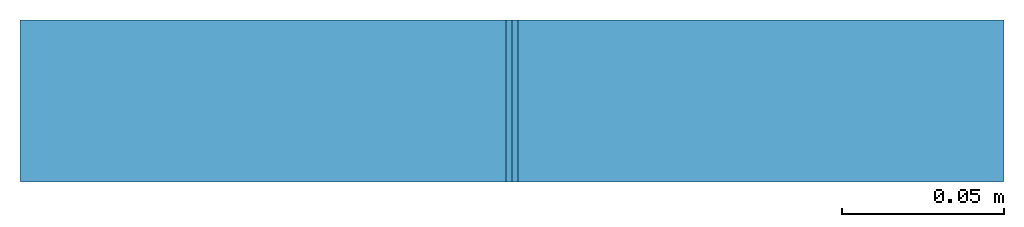
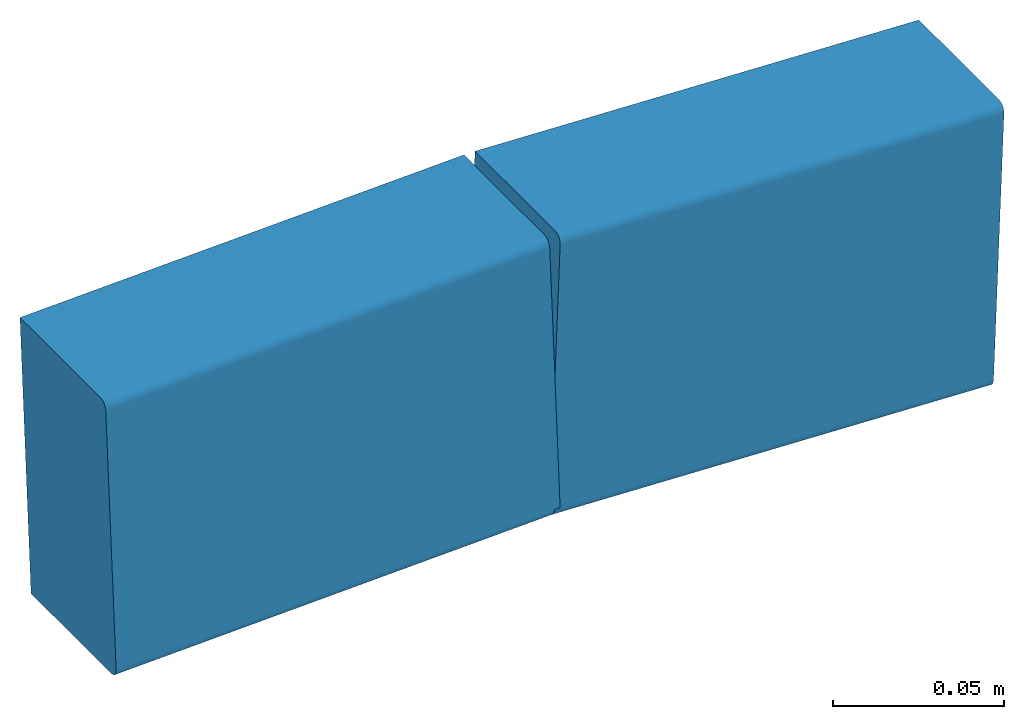
# One storey: 2 members.
"""IFC4 building model written with IfcOpenShell, lengths in metres."""

from ifc_helpers import new_model, entity, si_unit, derived_unit, frame, origin_with_axes, place, context, project, spatial, mirrored_profile, composite_profile, extrude, material, material_profile, profile_set, profile_usage, element, save


model = new_model("IFC4")

# Units and contexts
model_context = context("Model", 3, world=origin_with_axes())
ifc_project = project(units=[si_unit("LENGTHUNIT", "METRE"), si_unit("AREAUNIT", "SQUARE_METRE"), si_unit("VOLUMEUNIT", "CUBIC_METRE"), derived_unit("SECTIONMODULUSUNIT", [(si_unit("LENGTHUNIT", "METRE"), 3)]), derived_unit("MOMENTOFINERTIAUNIT", [(si_unit("LENGTHUNIT", "METRE"), 4)]), si_unit("PLANEANGLEUNIT", "RADIAN"), si_unit("TIMEUNIT", "SECOND"), si_unit("THERMODYNAMICTEMPERATUREUNIT", "DEGREE_CELSIUS"), derived_unit("THERMALEXPANSIONCOEFFICIENTUNIT", [(si_unit("THERMODYNAMICTEMPERATUREUNIT", "DEGREE_CELSIUS"), -1)])], contexts=[model_context])

# Site, building, storey
site = spatial("IfcSite", under=ifc_project, CompositionType="ELEMENT")
building = spatial("IfcBuilding", under=site, Name="Building", CompositionType="ELEMENT")
storey = spatial("IfcBuildingStorey", under=building, Name="TOP LEVEL", CompositionType="ELEMENT", Elevation=7.09966)

# Members
ifc_material = material(Name="SAE 1020")
cartesian_point_1 = entity("IfcCartesianPoint", [0.0044999998, 0.050000001])
ifc_direction_1 = entity("IfcDirection", [1.0, 0.0])
cartesian_point_2 = entity("IfcCartesianPoint", [0.0015, 0.046999998])
cartesian_point_3 = entity("IfcCartesianPoint", [0.0015, -0.046999998])
cartesian_point_4 = entity("IfcCartesianPoint", [0.0044999998, -0.050000001])
cartesian_point_5 = entity("IfcCartesianPoint", [0.0044999998, 0.050000001])
ifc_direction_2 = entity("IfcDirection", [1.0, 0.0])
cartesian_point_6 = entity("IfcCartesianPoint", [0.0015, 0.046999998])
cartesian_point_7 = entity("IfcCartesianPoint", [0.0015, -0.046999998])
cartesian_point_8 = entity("IfcCartesianPoint", [0.0044999998, -0.050000001])
ifc_material_profile_1 = material_profile(ifc_material, composite_profile([entity("IfcCenterLineProfileDef", "AREA", None, entity("IfcCompositeCurve", [entity("IfcCompositeCurveSegment", "CONTSAMEGRADIENT", True, entity("IfcPolyline", [entity("IfcCartesianPoint", [0.0515, 0.050000001]), cartesian_point_1])), entity("IfcCompositeCurveSegment", "CONTSAMEGRADIENT", True, entity("IfcTrimmedCurve", entity("IfcCircle", entity("IfcAxis2Placement2D", entity("IfcCartesianPoint", [0.0044999998, 0.047000002]), ifc_direction_1), 0.003), [cartesian_point_1], [cartesian_point_2], True, "CARTESIAN")), entity("IfcCompositeCurveSegment", "CONTSAMEGRADIENT", True, entity("IfcPolyline", [cartesian_point_2, cartesian_point_3])), entity("IfcCompositeCurveSegment", "CONTSAMEGRADIENT", True, entity("IfcTrimmedCurve", entity("IfcCircle", entity("IfcAxis2Placement2D", entity("IfcCartesianPoint", [0.0044999998, -0.047000002]), ifc_direction_1), 0.003), [cartesian_point_3], [cartesian_point_4], True, "CARTESIAN")), entity("IfcCompositeCurveSegment", "CONTSAMEGRADIENT", True, entity("IfcPolyline", [cartesian_point_4, entity("IfcCartesianPoint", [0.0515, -0.050000001])]))], "UNKNOWN"), 0.003), mirrored_profile(entity("IfcCenterLineProfileDef", "AREA", None, entity("IfcCompositeCurve", [entity("IfcCompositeCurveSegment", "CONTSAMEGRADIENT", True, entity("IfcPolyline", [entity("IfcCartesianPoint", [0.0515, 0.050000001]), cartesian_point_5])), entity("IfcCompositeCurveSegment", "CONTSAMEGRADIENT", True, entity("IfcTrimmedCurve", entity("IfcCircle", entity("IfcAxis2Placement2D", entity("IfcCartesianPoint", [0.0044999998, 0.047000002]), ifc_direction_2), 0.003), [cartesian_point_5], [cartesian_point_6], True, "CARTESIAN")), entity("IfcCompositeCurveSegment", "CONTSAMEGRADIENT", True, entity("IfcPolyline", [cartesian_point_6, cartesian_point_7])), entity("IfcCompositeCurveSegment", "CONTSAMEGRADIENT", True, entity("IfcTrimmedCurve", entity("IfcCircle", entity("IfcAxis2Placement2D", entity("IfcCartesianPoint", [0.0044999998, -0.047000002]), ifc_direction_2), 0.003), [cartesian_point_7], [cartesian_point_8], True, "CARTESIAN")), entity("IfcCompositeCurveSegment", "CONTSAMEGRADIENT", True, entity("IfcPolyline", [cartesian_point_8, entity("IfcCartesianPoint", [0.0515, -0.050000001])]))], "UNKNOWN"), 0.003))]))
ifc_profile_set_1 = profile_set([ifc_material_profile_1])
ifc_profile_usage_1 = profile_usage(ifc_profile_set_1, cardinal=10)
member_1_placement = place(None, frame((15.099845, 3.166, 7.094078), z_axis=(0.99930329, 0.0, 0.037321907), x_axis=(0.0, 1.0, 0.0)))
cartesian_point_9 = entity("IfcCartesianPoint", [0.0044999998, 0.050000001])
ifc_direction_3 = entity("IfcDirection", [1.0, 0.0])
cartesian_point_10 = entity("IfcCartesianPoint", [0.0015, 0.046999998])
cartesian_point_11 = entity("IfcCartesianPoint", [0.0015, -0.046999998])
cartesian_point_12 = entity("IfcCartesianPoint", [0.0044999998, -0.050000001])
cartesian_point_13 = entity("IfcCartesianPoint", [0.0044999998, 0.050000001])
ifc_direction_4 = entity("IfcDirection", [1.0, 0.0])
cartesian_point_14 = entity("IfcCartesianPoint", [0.0015, 0.046999998])
cartesian_point_15 = entity("IfcCartesianPoint", [0.0015, -0.046999998])
cartesian_point_16 = entity("IfcCartesianPoint", [0.0044999998, -0.050000001])
element("IfcMember", 1, at=member_1_placement, inside=storey, material=ifc_profile_usage_1, Name="242", context=model_context, shape_type="SweptSolid", body=[
    extrude(composite_profile([entity("IfcCenterLineProfileDef", "AREA", None, entity("IfcCompositeCurve", [entity("IfcCompositeCurveSegment", "CONTSAMEGRADIENT", True, entity("IfcPolyline", [entity("IfcCartesianPoint", [0.0515, 0.050000001]), cartesian_point_9])), entity("IfcCompositeCurveSegment", "CONTSAMEGRADIENT", True, entity("IfcTrimmedCurve", entity("IfcCircle", entity("IfcAxis2Placement2D", entity("IfcCartesianPoint", [0.0044999998, 0.047000002]), ifc_direction_3), 0.003), [cartesian_point_9], [cartesian_point_10], True, "CARTESIAN")), entity("IfcCompositeCurveSegment", "CONTSAMEGRADIENT", True, entity("IfcPolyline", [cartesian_point_10, cartesian_point_11])), entity("IfcCompositeCurveSegment", "CONTSAMEGRADIENT", True, entity("IfcTrimmedCurve", entity("IfcCircle", entity("IfcAxis2Placement2D", entity("IfcCartesianPoint", [0.0044999998, -0.047000002]), ifc_direction_3), 0.003), [cartesian_point_11], [cartesian_point_12], True, "CARTESIAN")), entity("IfcCompositeCurveSegment", "CONTSAMEGRADIENT", True, entity("IfcPolyline", [cartesian_point_12, entity("IfcCartesianPoint", [0.0515, -0.050000001])]))], "UNKNOWN"), 0.003), mirrored_profile(entity("IfcCenterLineProfileDef", "AREA", None, entity("IfcCompositeCurve", [entity("IfcCompositeCurveSegment", "CONTSAMEGRADIENT", True, entity("IfcPolyline", [entity("IfcCartesianPoint", [0.0515, 0.050000001]), cartesian_point_13])), entity("IfcCompositeCurveSegment", "CONTSAMEGRADIENT", True, entity("IfcTrimmedCurve", entity("IfcCircle", entity("IfcAxis2Placement2D", entity("IfcCartesianPoint", [0.0044999998, 0.047000002]), ifc_direction_4), 0.003), [cartesian_point_13], [cartesian_point_14], True, "CARTESIAN")), entity("IfcCompositeCurveSegment", "CONTSAMEGRADIENT", True, entity("IfcPolyline", [cartesian_point_14, cartesian_point_15])), entity("IfcCompositeCurveSegment", "CONTSAMEGRADIENT", True, entity("IfcTrimmedCurve", entity("IfcCircle", entity("IfcAxis2Placement2D", entity("IfcCartesianPoint", [0.0044999998, -0.047000002]), ifc_direction_4), 0.003), [cartesian_point_15], [cartesian_point_16], True, "CARTESIAN")), entity("IfcCompositeCurveSegment", "CONTSAMEGRADIENT", True, entity("IfcPolyline", [cartesian_point_16, entity("IfcCartesianPoint", [0.0515, -0.050000001])]))], "UNKNOWN"), 0.003))]), origin_with_axes(), (0.0, 0.0, 1.0), 0.15007784),
])
cartesian_point_17 = entity("IfcCartesianPoint", [0.0044999998, 0.050000001])
ifc_direction_5 = entity("IfcDirection", [1.0, 0.0])
cartesian_point_18 = entity("IfcCartesianPoint", [0.0015, 0.046999998])
cartesian_point_19 = entity("IfcCartesianPoint", [0.0015, -0.046999998])
cartesian_point_20 = entity("IfcCartesianPoint", [0.0044999998, -0.050000001])
cartesian_point_21 = entity("IfcCartesianPoint", [0.0044999998, 0.050000001])
ifc_direction_6 = entity("IfcDirection", [1.0, 0.0])
cartesian_point_22 = entity("IfcCartesianPoint", [0.0015, 0.046999998])
cartesian_point_23 = entity("IfcCartesianPoint", [0.0015, -0.046999998])
cartesian_point_24 = entity("IfcCartesianPoint", [0.0044999998, -0.050000001])
ifc_material_profile_2 = material_profile(ifc_material, composite_profile([entity("IfcCenterLineProfileDef", "AREA", None, entity("IfcCompositeCurve", [entity("IfcCompositeCurveSegment", "CONTSAMEGRADIENT", True, entity("IfcPolyline", [entity("IfcCartesianPoint", [0.0515, 0.050000001]), cartesian_point_17])), entity("IfcCompositeCurveSegment", "CONTSAMEGRADIENT", True, entity("IfcTrimmedCurve", entity("IfcCircle", entity("IfcAxis2Placement2D", entity("IfcCartesianPoint", [0.0044999998, 0.047000002]), ifc_direction_5), 0.003), [cartesian_point_17], [cartesian_point_18], True, "CARTESIAN")), entity("IfcCompositeCurveSegment", "CONTSAMEGRADIENT", True, entity("IfcPolyline", [cartesian_point_18, cartesian_point_19])), entity("IfcCompositeCurveSegment", "CONTSAMEGRADIENT", True, entity("IfcTrimmedCurve", entity("IfcCircle", entity("IfcAxis2Placement2D", entity("IfcCartesianPoint", [0.0044999998, -0.047000002]), ifc_direction_5), 0.003), [cartesian_point_19], [cartesian_point_20], True, "CARTESIAN")), entity("IfcCompositeCurveSegment", "CONTSAMEGRADIENT", True, entity("IfcPolyline", [cartesian_point_20, entity("IfcCartesianPoint", [0.0515, -0.050000001])]))], "UNKNOWN"), 0.003), mirrored_profile(entity("IfcCenterLineProfileDef", "AREA", None, entity("IfcCompositeCurve", [entity("IfcCompositeCurveSegment", "CONTSAMEGRADIENT", True, entity("IfcPolyline", [entity("IfcCartesianPoint", [0.0515, 0.050000001]), cartesian_point_21])), entity("IfcCompositeCurveSegment", "CONTSAMEGRADIENT", True, entity("IfcTrimmedCurve", entity("IfcCircle", entity("IfcAxis2Placement2D", entity("IfcCartesianPoint", [0.0044999998, 0.047000002]), ifc_direction_6), 0.003), [cartesian_point_21], [cartesian_point_22], True, "CARTESIAN")), entity("IfcCompositeCurveSegment", "CONTSAMEGRADIENT", True, entity("IfcPolyline", [cartesian_point_22, cartesian_point_23])), entity("IfcCompositeCurveSegment", "CONTSAMEGRADIENT", True, entity("IfcTrimmedCurve", entity("IfcCircle", entity("IfcAxis2Placement2D", entity("IfcCartesianPoint", [0.0044999998, -0.047000002]), ifc_direction_6), 0.003), [cartesian_point_23], [cartesian_point_24], True, "CARTESIAN")), entity("IfcCompositeCurveSegment", "CONTSAMEGRADIENT", True, entity("IfcPolyline", [cartesian_point_24, entity("IfcCartesianPoint", [0.0515, -0.050000001])]))], "UNKNOWN"), 0.003))]))
ifc_profile_set_2 = profile_set([ifc_material_profile_2])
ifc_profile_usage_2 = profile_usage(ifc_profile_set_2, cardinal=10)
member_2_placement = place(None, frame((15.249819, 3.166, 7.09966), z_axis=(0.99929685, 0.0, -0.037494075), x_axis=(0.0, 1.0, 0.0)))
cartesian_point_25 = entity("IfcCartesianPoint", [0.0044999998, 0.050000001])
ifc_direction_7 = entity("IfcDirection", [1.0, 0.0])
cartesian_point_26 = entity("IfcCartesianPoint", [0.0015, 0.046999998])
cartesian_point_27 = entity("IfcCartesianPoint", [0.0015, -0.046999998])
cartesian_point_28 = entity("IfcCartesianPoint", [0.0044999998, -0.050000001])
cartesian_point_29 = entity("IfcCartesianPoint", [0.0044999998, 0.050000001])
ifc_direction_8 = entity("IfcDirection", [1.0, 0.0])
cartesian_point_30 = entity("IfcCartesianPoint", [0.0015, 0.046999998])
cartesian_point_31 = entity("IfcCartesianPoint", [0.0015, -0.046999998])
cartesian_point_32 = entity("IfcCartesianPoint", [0.0044999998, -0.050000001])
element("IfcMember", 2, at=member_2_placement, inside=storey, material=ifc_profile_usage_2, Name="243", context=model_context, shape_type="SweptSolid", body=[
    extrude(composite_profile([entity("IfcCenterLineProfileDef", "AREA", None, entity("IfcCompositeCurve", [entity("IfcCompositeCurveSegment", "CONTSAMEGRADIENT", True, entity("IfcPolyline", [entity("IfcCartesianPoint", [0.0515, 0.050000001]), cartesian_point_25])), entity("IfcCompositeCurveSegment", "CONTSAMEGRADIENT", True, entity("IfcTrimmedCurve", entity("IfcCircle", entity("IfcAxis2Placement2D", entity("IfcCartesianPoint", [0.0044999998, 0.047000002]), ifc_direction_7), 0.003), [cartesian_point_25], [cartesian_point_26], True, "CARTESIAN")), entity("IfcCompositeCurveSegment", "CONTSAMEGRADIENT", True, entity("IfcPolyline", [cartesian_point_26, cartesian_point_27])), entity("IfcCompositeCurveSegment", "CONTSAMEGRADIENT", True, entity("IfcTrimmedCurve", entity("IfcCircle", entity("IfcAxis2Placement2D", entity("IfcCartesianPoint", [0.0044999998, -0.047000002]), ifc_direction_7), 0.003), [cartesian_point_27], [cartesian_point_28], True, "CARTESIAN")), entity("IfcCompositeCurveSegment", "CONTSAMEGRADIENT", True, entity("IfcPolyline", [cartesian_point_28, entity("IfcCartesianPoint", [0.0515, -0.050000001])]))], "UNKNOWN"), 0.003), mirrored_profile(entity("IfcCenterLineProfileDef", "AREA", None, entity("IfcCompositeCurve", [entity("IfcCompositeCurveSegment", "CONTSAMEGRADIENT", True, entity("IfcPolyline", [entity("IfcCartesianPoint", [0.0515, 0.050000001]), cartesian_point_29])), entity("IfcCompositeCurveSegment", "CONTSAMEGRADIENT", True, entity("IfcTrimmedCurve", entity("IfcCircle", entity("IfcAxis2Placement2D", entity("IfcCartesianPoint", [0.0044999998, 0.047000002]), ifc_direction_8), 0.003), [cartesian_point_29], [cartesian_point_30], True, "CARTESIAN")), entity("IfcCompositeCurveSegment", "CONTSAMEGRADIENT", True, entity("IfcPolyline", [cartesian_point_30, cartesian_point_31])), entity("IfcCompositeCurveSegment", "CONTSAMEGRADIENT", True, entity("IfcTrimmedCurve", entity("IfcCircle", entity("IfcAxis2Placement2D", entity("IfcCartesianPoint", [0.0044999998, -0.047000002]), ifc_direction_8), 0.003), [cartesian_point_31], [cartesian_point_32], True, "CARTESIAN")), entity("IfcCompositeCurveSegment", "CONTSAMEGRADIENT", True, entity("IfcPolyline", [cartesian_point_32, entity("IfcCartesianPoint", [0.0515, -0.050000001])]))], "UNKNOWN"), 0.003))]), origin_with_axes(), (0.0, 0.0, 1.0), 0.15003987),
])

save(model, "model.ifc")
